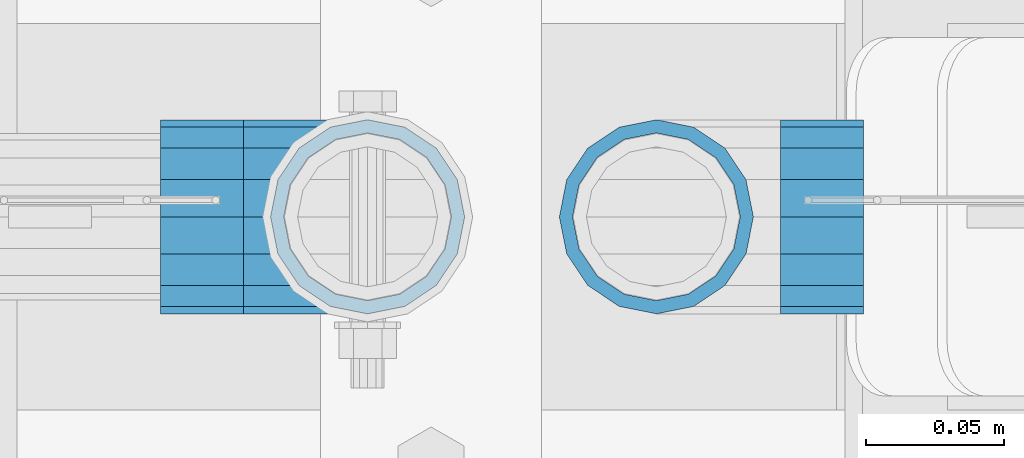
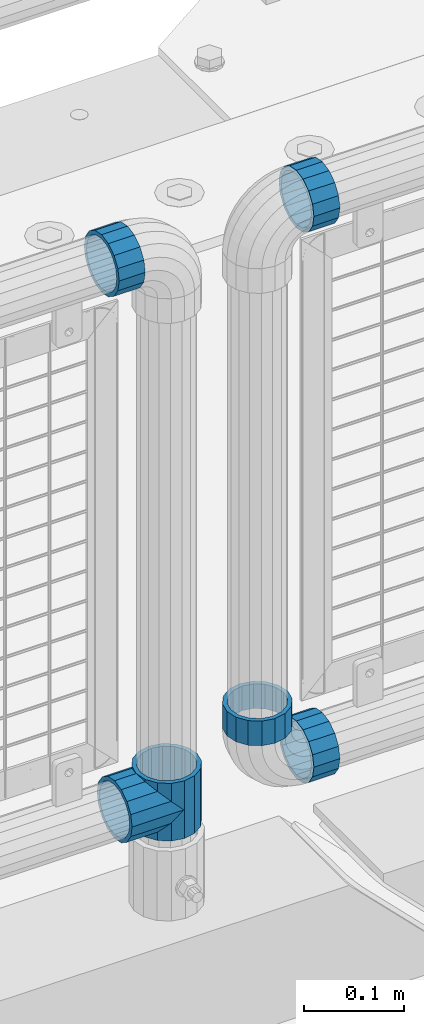
# One storey, part 144 of 219: 6 beams.
"""IFC2X3 building model written with IfcOpenShell, lengths in millimetres."""

import ifcopenshell
import ifcopenshell.guid

model = None  # the IFC model being written
_history = None  # IfcOwnerHistory: only IFC2X3 demands one
_inside = {}  # id of a spatial element -> (the spatial element, [elements in it])
_under = {}  # id of a project, library or spatial element -> (it, [spatial elements below it])
_declared = {}  # id of a project -> (the project, [libraries it declares])
_typed = {}  # id of a type object -> (the type object, [elements of that type])
_made_of = {}  # id of a material, layer set ... -> (it, [elements and type objects made of it])


def new_model(schema):
    """Start an empty IFC model of exactly this schema.

    Asked for "IFC4X3", IfcOpenShell would pick the latest addendum, in which some entities
    have other attributes; the version numbers below select the first issue.
    IFC2X3 requires an IfcOwnerHistory on every rooted entity: one is made here for all.
    """
    global model, _history
    if schema == "IFC4X3":
        model = ifcopenshell.file(schema_version=(4, 3, 0, 0))
    else:
        model = ifcopenshell.file(schema=schema)
    _inside.clear()
    _under.clear()
    _declared.clear()
    _typed.clear()
    _made_of.clear()
    _history = None
    if model.schema == "IFC2X3":
        org = make("IfcOrganization", Name="unknown")
        user = make(
            "IfcPersonAndOrganization",
            ThePerson=make("IfcPerson", FamilyName="unknown"),
            TheOrganization=org,
        )
        app = make(
            "IfcApplication",
            ApplicationDeveloper=org,
            Version="unknown",
            ApplicationFullName="unknown",
            ApplicationIdentifier="unknown",
        )
        _history = make(
            "IfcOwnerHistory",
            OwningUser=user,
            OwningApplication=app,
            ChangeAction="ADDED",
            CreationDate=0,
        )
    return model


def make(cls, **values):
    """One entity of the class cls with the attributes given. An attribute that is None is left unset."""
    return model.create_entity(
        cls, **{name: value for name, value in values.items() if value is not None}
    )


def rooted(cls, **values):
    """An entity with a GlobalId (a new one), such as an element, a storey or a relation."""
    return make(cls, GlobalId=ifcopenshell.guid.new(), OwnerHistory=_history, **values)


def si_unit(unit_type, name, prefix=None):
    """IfcSIUnit, for example si_unit("LENGTHUNIT", "METRE", prefix="MILLI")."""
    return make("IfcSIUnit", UnitType=unit_type, Prefix=prefix, Name=name)


def assignment(units):
    """IfcUnitAssignment: the units of a project."""
    return None if units is None else make("IfcUnitAssignment", Units=units)


def point(xyz):
    """IfcCartesianPoint."""
    return None if xyz is None else make("IfcCartesianPoint", Coordinates=xyz)


def direction(xyz):
    """IfcDirection."""
    return None if xyz is None else make("IfcDirection", DirectionRatios=xyz)


def frame(location, z_axis=None, x_axis=None):
    """IfcAxis2Placement3D, a coordinate frame: its origin and axes. An axis left out is left unset."""
    return make(
        "IfcAxis2Placement3D",
        Location=point(location),
        Axis=direction(z_axis),
        RefDirection=direction(x_axis),
    )


def origin_with_axes():
    """The frame at (0, 0, 0) with the z axis (0, 0, 1) and the x axis (1, 0, 0) written out."""
    return frame((0.0, 0.0, 0.0), z_axis=(0.0, 0.0, 1.0), x_axis=(1.0, 0.0, 0.0))


def place(relative_to, where):
    """IfcLocalPlacement: puts the frame where relative to a parent placement (None: the world)."""
    return make(
        "IfcLocalPlacement", PlacementRelTo=relative_to, RelativePlacement=where
    )


def context(
    kind, dimensions, precision=None, world=None, true_north=None, identifier=None
):
    """IfcGeometricRepresentationContext, for example the 3D "Model" context."""
    return make(
        "IfcGeometricRepresentationContext",
        ContextIdentifier=identifier,
        ContextType=kind,
        CoordinateSpaceDimension=dimensions,
        Precision=precision,
        WorldCoordinateSystem=world,
        TrueNorth=true_north,
    )


def subcontext(parent, identifier, kind, view, scale=None):
    """IfcGeometricRepresentationSubContext, for example "Body" below "Model"."""
    return make(
        "IfcGeometricRepresentationSubContext",
        ContextIdentifier=identifier,
        ContextType=kind,
        ParentContext=parent,
        TargetScale=scale,
        TargetView=view,
    )


def project(units=None, contexts=None):
    """IfcProject with its units and contexts."""
    return rooted(
        "IfcProject",
        Name="project",
        RepresentationContexts=contexts,
        UnitsInContext=assignment(units),
    )


def spatial(cls, under=None, at=None, **own):
    """A site, building, storey or space (cls), placed at a placement, below another one or the project."""
    s = rooted(cls, ObjectPlacement=at, **own)
    if under is not None:
        _under.setdefault(under.id(), (under, []))[1].append(s)
    return s


def faces_of(points, faces, orient=None, outer=None):
    """IfcFace entities. A face is a list of loops; a loop is a list of indices into points, from 0.

    orient and outer hold one flag for each loop. By default every Orientation is true, the
    first loop of a face is its IfcFaceOuterBound and the others are IfcFaceBound.
    """
    made = []
    for i, loops in enumerate(faces):
        bounds = []
        for j, loop in enumerate(loops):
            is_outer = j == 0 if outer is None else outer[i][j]
            bounds.append(
                make(
                    "IfcFaceOuterBound" if is_outer else "IfcFaceBound",
                    Bound=make("IfcPolyLoop", Polygon=[points[k] for k in loop]),
                    Orientation=True if orient is None else orient[i][j],
                )
            )
        made.append(make("IfcFace", Bounds=bounds))
    return made


def faceted_brep(points, faces, orient=None, outer=None, voids=None):
    """IfcFacetedBrep: a solid bounded by flat faces; with voids (closed shells), ...WithVoids."""
    shared = [point(p) for p in points]
    hull = make("IfcClosedShell", CfsFaces=faces_of(shared, faces, orient, outer))
    if voids is None:
        return make("IfcFacetedBrep", Outer=hull)
    return make(
        "IfcFacetedBrepWithVoids",
        Outer=hull,
        Voids=[
            make(cls, CfsFaces=faces_of(shared, fs, o, b)) for cls, fs, o, b in voids
        ],
    )


def shape(context_of_items, identifier, shape_type, items):
    """IfcShapeRepresentation: the items that make up one representation, for example the "Body"."""
    return make(
        "IfcShapeRepresentation",
        ContextOfItems=context_of_items,
        RepresentationIdentifier=identifier,
        RepresentationType=shape_type,
        Items=items,
    )


def material(Name=None, Category=None):
    """IfcMaterial."""
    return make("IfcMaterial", Name=Name, Category=Category)


def made_of(thing, what):
    """Note that an element or type object is made of a material, layer set ...; save() writes the relation."""
    if what is not None:
        _made_of.setdefault(what.id(), (what, []))[1].append(thing)
    return thing


def type_object(cls, material=None, **own):
    """A type object (cls), such as IfcWallType, which elements share."""
    return made_of(rooted(cls, **own), material)


def element(
    cls,
    number,
    at=None,
    inside=None,
    cuts=None,
    type_object=None,
    material=None,
    context=None,
    identifier="Body",
    shape_type=None,
    held_by="IfcProductDefinitionShape",
    body=None,
    shapes=None,
    **own,
):
    """One element of the class cls, such as IfcWall. Its Tag is "e" and its number.

    at: its placement. inside: the storey or other place that contains it. cuts: it is an
    opening in that element (IfcRelVoidsElement). A single representation is given by context,
    identifier, shape_type and body (its items); several are given by shapes. held_by: the class
    of the entity that holds the representations. save() writes the other relations.
    """
    e = rooted(cls, Tag="e%d" % number, ObjectPlacement=at, **own)
    if body is not None:
        shapes = [shape(context, identifier, shape_type, body)]
    if shapes is not None:
        e.Representation = make(held_by, Representations=shapes)
    if inside is not None:
        _inside.setdefault(inside.id(), (inside, []))[1].append(e)
    if cuts is not None:
        rooted(
            "IfcRelVoidsElement", RelatingBuildingElement=cuts, RelatedOpeningElement=e
        )
    if type_object is not None:
        _typed.setdefault(type_object.id(), (type_object, []))[1].append(e)
    return made_of(e, material)


def aggregate(whole, parts):
    """IfcRelAggregates: a whole, such as a stair, and the parts it consists of."""
    return rooted("IfcRelAggregates", RelatingObject=whole, RelatedObjects=parts)


def save(model, path):
    """Write the relations noted so far, then the file.

    IfcRelAggregates (storeys below a building ...), IfcRelContainedInSpatialStructure (elements
    in a storey), IfcRelDefinesByType, IfcRelAssociatesMaterial and IfcRelDeclares: one each for
    every whole, place, type object, material and project.
    """
    for whole, parts in _under.values():
        aggregate(whole, parts)
    for where, things in _inside.values():
        rooted(
            "IfcRelContainedInSpatialStructure",
            RelatedElements=things,
            RelatingStructure=where,
        )
    for kind, things in _typed.values():
        rooted("IfcRelDefinesByType", RelatedObjects=things, RelatingType=kind)
    for what, things in _made_of.values():
        rooted("IfcRelAssociatesMaterial", RelatedObjects=things, RelatingMaterial=what)
    for by, libraries in _declared.values():
        rooted("IfcRelDeclares", RelatingContext=by, RelatedDefinitions=libraries)
    model.write(path)


model = new_model("IFC2X3")

# Units and contexts
model_context = context("Model", 3, precision=1e-05, world=origin_with_axes())
body_context = subcontext(model_context, "Body", "Model", "MODEL_VIEW")
ifc_project = project(units=[si_unit("LENGTHUNIT", "METRE", prefix="MILLI"), si_unit("AREAUNIT", "SQUARE_METRE"), si_unit("VOLUMEUNIT", "CUBIC_METRE"), si_unit("MASSUNIT", "GRAM", prefix="KILO"), si_unit("TIMEUNIT", "SECOND"), si_unit("PLANEANGLEUNIT", "RADIAN"), si_unit("SOLIDANGLEUNIT", "STERADIAN"), si_unit("THERMODYNAMICTEMPERATUREUNIT", "DEGREE_CELSIUS"), si_unit("LUMINOUSINTENSITYUNIT", "LUMEN")], contexts=[model_context])

# Site, building, storey
site_placement = place(None, origin_with_axes())
site = spatial("IfcSite", under=ifc_project, at=site_placement, CompositionType="ELEMENT")
building_placement = place(site_placement, origin_with_axes())
building = spatial("IfcBuilding", under=site, at=building_placement, Name="Standard", CompositionType="ELEMENT")
storey_placement = place(building_placement, origin_with_axes())
storey = spatial("IfcBuildingStorey", under=building, at=storey_placement, Name="Undefined", CompositionType="ELEMENT", Elevation=0.0)

# Beams
ifc_material = material(Name="Misc_Undefined")
beam_type = type_object("IfcBeamType", PredefinedType="NOTDEFINED")
beam_1_placement = place(storey_placement, frame((12227.0, 31664.5, 298.670000000001), z_axis=(0.0, 1.0, 0.0), x_axis=(-1.0, 0.0, 0.0)))
element("IfcBeam", 1, at=beam_1_placement, inside=storey, type_object=beam_type, material=ifc_material, context=body_context, shape_type="Brep", body=[
    faceted_brep([(0.0, 0.0, -35.1500000000015), (13.4513226476338, -13.4513226476329, -32.4743655677703), (13.4513226476338, 13.4513226476329, -32.4743655677703), (27.1226768591096, -21.4606908090117, 21.46069080901), (32.4743655677721, -26.8123795176755, 13.4513226476338), (32.4743655677721, -32.4743655677717, 13.4513226476338), (24.8548033587067, -24.8548033587072, 24.8548033587067), (24.8548033587067, -16.3810424080013, 24.8548033587067), (32.8397438117172, -28.0397438117175, 11.614442172282), (35.1499999999996, -30.35, 0.0), (35.1499999999996, -35.15, 0.0), (32.4743655677721, -26.8123795176712, -13.4513226476338), (32.4743655677721, -32.4743655677717, -13.4513226476338), (32.8397438117172, -28.0397438117175, -11.614442172282), (24.8548033587067, -16.3810424080013, -24.8548033587067), (24.8548033587067, -24.8548033587072, -24.8548033587067), (27.1226768591077, -21.4606908090117, -21.46069080901), (20.0882031229739, -11.6144421722805, -28.0397438117179), (16.6306603983649, 0.0, -30.3499999999985), (20.0882031229739, 11.6144421722805, -28.0397438117179), (24.8548033587067, 16.3810424080013, -24.8548033587067), (24.8548033587067, 24.8548033587072, -24.8548033587067), (27.1226768591077, 21.4606908090117, -21.46069080901), (32.4743655677721, 26.8123795176755, -13.4513226476338), (32.4743655677721, 32.4743655677717, -13.4513226476338), (32.8397438117172, 28.0397438117175, -11.614442172282), (35.1499999999996, 30.35, 0.0), (35.1499999999996, 35.15, 0.0), (32.8397438117172, 28.0397438117175, 11.614442172282), (32.4743655677721, 26.8123795176755, 13.4513226476338), (32.4743655677721, 32.4743655677717, 13.4513226476338), (27.1226768591096, 21.4606908090117, 21.46069080901), (24.8548033587067, 16.3810424080078, 24.8548033587067), (24.8548033587067, 24.8548033587072, 24.8548033587067), (0.0, 0.0, 35.1500000000015), (13.4513226476338, 13.4513226476329, 32.4743655677703), (13.4513226476338, -13.4513226476329, 32.4743655677703), (20.0882031229849, 11.6144421722805, 28.0397438117179), (16.6306603983739, 0.0, 30.3499999999985), (20.0882031229849, -11.6144421722805, 28.0397438117179), (60.1499999999996, -35.15, 0.0), (60.1499999999996, -32.4743655677717, 13.4513226476338), (60.1499999999996, -24.8548033587072, 24.8548033587067), (60.1499999999996, -13.4513226476329, 32.4743655677703), (60.1499999999996, 0.0, 35.1500000000015), (60.1499999999996, -24.8548033587072, -24.8548033587067), (60.1499999999996, -32.4743655677717, -13.4513226476338), (60.1499999999996, -13.4513226476329, -32.4743655677703), (60.1499999999996, 0.0, -35.1500000000015), (60.1499999999996, 13.4513226476329, -32.4743655677703), (60.1499999999996, 24.8548033587072, -24.8548033587067), (60.1499999999996, 32.4743655677717, -13.4513226476338), (60.1499999999996, 35.15, 0.0), (60.1499999999996, 32.4743655677717, 13.4513226476338), (60.1499999999996, 24.8548033587072, 24.8548033587067), (60.1499999999996, 13.4513226476329, 32.4743655677703), (60.1499999999996, -21.4606908090117, 21.46069080901), (60.1499999999996, -11.6144421722805, 28.0397438117179), (60.1499999999996, 0.0, 30.3499999999985), (60.1499999999996, 11.6144421722805, 28.0397438117179), (60.1499999999996, 21.4606908090117, 21.46069080901), (60.1499999999996, 28.0397438117175, 11.614442172282), (60.1499999999996, 30.35, 0.0), (60.1499999999996, 28.0397438117175, -11.614442172282), (60.1499999999996, 21.4606908090117, -21.46069080901), (60.1499999999996, 11.6144421722805, -28.0397438117179), (60.1499999999996, 0.0, -30.3499999999985), (60.1499999999996, -11.6144421722805, -28.0397438117179), (60.1499999999996, -21.4606908090117, -21.46069080901), (60.1499999999996, -28.0397438117175, -11.614442172282), (60.1499999999996, -30.35, 0.0), (60.1499999999996, -28.0397438117175, 11.614442172282)], [[[0, 1, 2]], [[3, 4, 5, 6, 7]], [[8, 9, 10, 5, 4]], [[11, 12, 10, 9, 13]], [[14, 15, 12, 11, 16]], [[2, 1, 15, 14, 17, 18, 19, 20, 21]], [[21, 20, 22, 23, 24]], [[24, 23, 25, 26, 27]], [[27, 26, 28, 29, 30]], [[30, 29, 31, 32, 33]], [[34, 35, 36]], [[33, 32, 37, 38, 39, 7, 6, 36, 35]], [[40, 41, 5, 10]], [[41, 42, 6, 5]], [[42, 43, 36, 6]], [[43, 44, 34, 36]], [[45, 46, 12, 15]], [[47, 45, 15, 1]], [[48, 47, 1, 0]], [[49, 48, 0, 2]], [[50, 49, 2, 21]], [[51, 50, 21, 24]], [[52, 51, 24, 27]], [[53, 52, 27, 30]], [[54, 53, 30, 33]], [[55, 54, 33, 35]], [[44, 55, 35, 34]], [[46, 40, 10, 12]], [[45, 47, 48, 49, 50, 51, 52, 53, 54, 55, 44, 43, 42, 41, 40, 46], [56, 57, 58, 59, 60, 61, 62, 63, 64, 65, 66, 67, 68, 69, 70, 71]], [[59, 58, 38, 37]], [[31, 60, 59, 37, 32]], [[28, 61, 60, 31, 29]], [[62, 61, 28, 26]], [[63, 62, 26, 25]], [[64, 63, 25, 23, 22]], [[65, 64, 22, 20, 19]], [[66, 65, 19, 18]], [[67, 66, 18, 17]], [[16, 68, 67, 17, 14]], [[13, 69, 68, 16, 11]], [[70, 69, 13, 9]], [[71, 70, 9, 8]], [[56, 71, 8, 4, 3]], [[57, 56, 3, 7, 39]], [[58, 57, 39, 38]]]),
])
beam_2_placement = place(storey_placement, frame((12227.0, 31664.5, 333.820000000001), z_axis=(1.0, 0.0, 0.0), x_axis=(0.0, 0.0, -1.0)))
element("IfcBeam", 2, at=beam_2_placement, inside=storey, type_object=beam_type, material=ifc_material, context=body_context, shape_type="Brep", body=[
    faceted_brep([(46.7644421722801, 28.0397438117179, -11.6144421722802), (46.7644421722801, 28.0397438117179, -20.0882031229849), (51.5310424080006, 24.8548033587067, -24.8548033587067), (56.6106908090114, 21.46069080901, -27.1226768591096), (56.6106908090114, 21.46069080901, -21.4606908090118), (61.9623795176703, 13.4513226476338, -32.4743655677721), (63.1897438117172, 11.614442172282, -32.8397438117172), (63.1897438117172, 11.614442172282, -28.0397438117179), (65.4999999999997, 0.0, -35.1499999999996), (65.4999999999997, 0.0, -30.3500000000004), (63.1897438117172, -11.614442172282, -32.839743811719), (63.1897438117172, -11.614442172282, -28.0397438117179), (61.9623795176747, -13.4513226476338, -32.4743655677721), (56.6106908090114, -21.46069080901, -27.1226768591077), (56.6106908090114, -21.46069080901, -21.4606908090118), (51.5310424080006, -24.8548033587067, -24.8548033587067), (46.7644421722801, -28.0397438117179, -20.0882031229739), (46.7644421722801, -28.0397438117179, -11.6144421722802), (35.1499999999996, -30.3499999999985, -16.6306603983649), (35.1499999999996, -30.35, 0.0), (23.5355578277191, -28.0397438117179, -20.0882031229739), (23.5355578277191, -28.0397438117179, -11.6144421722802), (18.7689575919921, -24.8548033587067, -24.8548033587067), (13.6893091909879, -21.46069080901, -27.1226768591077), (13.6893091909879, -21.46069080901, -21.4606908090118), (8.33762048232455, -13.4513226476338, -32.4743655677721), (7.11025618828211, -11.614442172282, -32.839743811719), (7.11025618828211, -11.614442172282, -28.0397438117179), (4.79999999999961, 0.0, -35.1499999999996), (4.79999999999961, 0.0, -30.3500000000004), (7.11025618828211, 11.614442172282, -32.8397438117172), (7.11025618828211, 11.614442172282, -28.0397438117179), (8.33762048232455, 13.4513226476338, -32.4743655677721), (13.6893091909879, 21.46069080901, -27.1226768591096), (13.6893091909879, 21.46069080901, -21.4606908090118), (18.7689575919987, 24.8548033587067, -24.8548033587067), (23.5355578277192, 28.0397438117179, -20.0882031229849), (23.5355578277192, 28.0397438117179, -11.6144421722802), (35.1499999999996, 30.3499999999985, -16.6306603983739), (35.1499999999996, 30.35, 0.0), (0.0, 32.4743655677703, -13.4513226476338), (0.0, 35.1500000000015, 0.0), (70.2999999999993, 35.1500000000015, 0.0), (70.2999999999993, 32.4743655677703, -13.4513226476338), (0.0, 32.4743655677703, 13.4513226476338), (70.2999999999993, 32.4743655677703, 13.4513226476338), (0.0, 24.8548033587067, 24.8548033587067), (70.2999999999993, 24.8548033587067, 24.8548033587067), (0.0, 13.4513226476338, 32.4743655677721), (70.2999999999993, 13.4513226476338, 32.4743655677721), (0.0, 0.0, 35.1500000000015), (70.2999999999993, 0.0, 35.1499999999996), (0.0, -13.4513226476338, 32.4743655677721), (70.2999999999993, -13.4513226476338, 32.4743655677721), (0.0, -24.8548033587067, 24.8548033587067), (70.2999999999993, -24.8548033587067, 24.8548033587067), (0.0, -32.4743655677703, 13.4513226476338), (70.2999999999993, -32.4743655677703, 13.4513226476338), (0.0, -35.1500000000015, 0.0), (70.2999999999993, -35.1500000000015, 0.0), (70.2999999999993, -30.3499999999985, 0.0), (70.2999999999993, -28.0397438117179, -11.6144421722802), (70.2999999999993, -21.46069080901, -21.4606908090118), (70.2999999999993, -11.614442172282, -28.0397438117179), (70.2999999999993, 0.0, -30.3500000000004), (70.2999999999993, 11.614442172282, -28.0397438117179), (70.2999999999993, 21.46069080901, -21.4606908090118), (70.2999999999993, 28.0397438117179, -11.6144421722802), (0.0, -28.0397438117179, -11.6144421722802), (0.0, -30.3499999999985, 0.0), (0.0, -21.46069080901, -21.4606908090118), (0.0, -11.614442172282, -28.0397438117179), (0.0, 0.0, -30.3500000000004), (0.0, 11.614442172282, -28.0397438117179), (0.0, 21.46069080901, -21.4606908090118), (0.0, 28.0397438117179, -11.6144421722802), (0.0, 30.3499999999985, 0.0), (70.2999999999993, 30.3499999999985, 0.0), (0.0, 28.0397438117179, 11.6144421722802), (70.2999999999993, 28.0397438117179, 11.6144421722802), (0.0, 21.46069080901, 21.4606908090118), (70.2999999999993, 21.46069080901, 21.4606908090118), (0.0, 11.614442172282, 28.0397438117179), (70.2999999999993, 11.614442172282, 28.0397438117179), (0.0, 0.0, 30.3500000000004), (70.2999999999993, 0.0, 30.3500000000004), (0.0, -11.614442172282, 28.0397438117179), (70.2999999999993, -11.614442172282, 28.0397438117179), (0.0, -21.46069080901, 21.4606908090118), (70.2999999999993, -21.46069080901, 21.4606908090118), (0.0, -28.0397438117179, 11.6144421722802), (70.2999999999993, -28.0397438117179, 11.6144421722802), (70.2999999999993, -24.8548033587067, -24.8548033587067), (70.2999999999993, -13.4513226476338, -32.4743655677721), (70.2999999999993, 0.0, -35.1499999999996), (70.2999999999993, 13.4513226476338, -32.4743655677721), (70.2999999999993, 24.8548033587067, -24.8548033587067), (70.2999999999993, -32.4743655677703, -13.4513226476338), (0.0, -32.4743655677703, -13.4513226476338), (0.0, 24.8548033587067, -24.8548033587067), (0.0, 13.4513226476338, -32.4743655677721), (0.0, 0.0, -35.1500000000015), (0.0, -13.4513226476338, -32.4743655677721), (0.0, -24.8548033587067, -24.8548033587067)], [[[0, 1, 2, 3, 4]], [[4, 3, 5, 6, 7]], [[7, 6, 8, 9]], [[9, 8, 10, 11]], [[11, 10, 12, 13, 14]], [[14, 13, 15, 16, 17]], [[17, 16, 18, 19]], [[19, 18, 20, 21]], [[21, 20, 22, 23, 24]], [[24, 23, 25, 26, 27]], [[27, 26, 28, 29]], [[29, 28, 30, 31]], [[31, 30, 32, 33, 34]], [[34, 33, 35, 36, 37]], [[37, 36, 38, 39]], [[39, 38, 1, 0]], [[40, 41, 42, 43]], [[41, 44, 45, 42]], [[44, 46, 47, 45]], [[46, 48, 49, 47]], [[48, 50, 51, 49]], [[50, 52, 53, 51]], [[52, 54, 55, 53]], [[54, 56, 57, 55]], [[56, 58, 59, 57]], [[60, 61, 17, 19]], [[61, 62, 14, 17]], [[62, 63, 11, 14]], [[63, 64, 9, 11]], [[64, 65, 7, 9]], [[65, 66, 4, 7]], [[66, 67, 0, 4]], [[68, 69, 19, 21]], [[70, 68, 21, 24]], [[71, 70, 24, 27]], [[72, 71, 27, 29]], [[73, 72, 29, 31]], [[74, 73, 31, 34]], [[75, 74, 34, 37]], [[76, 75, 37, 39]], [[67, 77, 39, 0]], [[78, 76, 39, 77, 79]], [[80, 78, 79, 81]], [[82, 80, 81, 83]], [[84, 82, 83, 85]], [[86, 84, 85, 87]], [[88, 86, 87, 89]], [[90, 88, 89, 91]], [[19, 69, 90, 91, 60]], [[92, 93, 94, 95, 96, 43, 42, 45, 47, 49, 51, 53, 55, 57, 59, 97], [89, 87, 85, 83, 81, 79, 77, 67, 66, 65, 64, 63, 62, 61, 60, 91]], [[58, 98, 97, 59]], [[56, 54, 52, 50, 48, 46, 44, 41, 40, 99, 100, 101, 102, 103, 98, 58], [68, 70, 71, 72, 73, 74, 75, 76, 78, 80, 82, 84, 86, 88, 90, 69]], [[32, 100, 99, 35, 33]], [[28, 101, 100, 32, 30]], [[102, 101, 28, 26, 25]], [[103, 102, 25, 23, 22]], [[15, 92, 97, 98, 103, 22, 20, 18, 16]], [[12, 93, 92, 15, 13]], [[8, 94, 93, 12, 10]], [[95, 94, 8, 6, 5]], [[96, 95, 5, 3, 2]], [[35, 99, 40, 43, 96, 2, 1, 38, 36]]]),
])
beam_3_placement = place(storey_placement, frame((12182.0, 31664.5, 969.85), z_axis=(0.0, 0.0, 1.0), x_axis=(-1.0, 0.0, 0.0)))
element("IfcBeam", 3, at=beam_3_placement, inside=storey, type_object=beam_type, material=ifc_material, context=body_context, shape_type="Brep", body=[
    faceted_brep([(0.0, -30.3499999999985, 0.0), (0.0, -28.0397438117179, 11.6144421722802), (30.0, -28.0397438117179, 11.6144421722805), (30.0, -30.3499999999985, 0.0), (0.0, -21.46069080901, 21.4606908090118), (30.0, -21.46069080901, 21.4606908090117), (0.0, -11.614442172282, 28.0397438117179), (30.0, -11.614442172282, 28.0397438117176), (0.0, 0.0, 30.3500000000004), (30.0, 0.0, 30.35), (0.0, 11.614442172282, 28.0397438117179), (30.0, 11.614442172282, 28.0397438117176), (0.0, 21.46069080901, 21.4606908090118), (30.0, 21.46069080901, 21.4606908090117), (0.0, 28.0397438117179, 11.6144421722802), (30.0, 28.0397438117179, 11.6144421722805), (0.0, 30.3499999999985, 0.0), (30.0, 30.3499999999985, 0.0), (0.0, 28.0397438117179, -11.6144421722802), (30.0, 28.0397438117179, -11.6144421722805), (0.0, 21.46069080901, -21.4606908090118), (30.0, 21.46069080901, -21.4606908090117), (0.0, 11.614442172282, -28.0397438117179), (30.0, 11.614442172282, -28.0397438117176), (0.0, 0.0, -30.3500000000004), (30.0, 0.0, -30.35), (0.0, -11.614442172282, -28.0397438117179), (30.0, -11.614442172282, -28.0397438117176), (0.0, -21.46069080901, -21.4606908090118), (30.0, -21.46069080901, -21.4606908090117), (0.0, -28.0397438117179, -11.6144421722802), (30.0, -28.0397438117179, -11.6144421722805), (0.0, -35.1500000000015, 0.0), (0.0, -32.4743655677703, -13.4513226476338), (30.0, -32.4743655677703, -13.4513226476329), (30.0, -35.1500000000015, 0.0), (0.0, -24.8548033587067, -24.8548033587067), (30.0, -24.8548033587067, -24.8548033587072), (0.0, -13.4513226476338, -32.4743655677721), (30.0, -13.4513226476338, -32.4743655677718), (0.0, 0.0, -35.1500000000015), (30.0, 0.0, -35.15), (0.0, 13.4513226476338, -32.4743655677721), (30.0, 13.4513226476338, -32.4743655677718), (0.0, 24.8548033587067, -24.8548033587067), (30.0, 24.8548033587067, -24.8548033587072), (0.0, 32.4743655677703, -13.4513226476338), (30.0, 32.4743655677703, -13.4513226476329), (0.0, 35.1500000000015, 0.0), (30.0, 35.1500000000015, 0.0), (0.0, 32.4743655677703, 13.4513226476338), (30.0, 32.4743655677703, 13.4513226476329), (0.0, 24.8548033587067, 24.8548033587067), (30.0, 24.8548033587067, 24.8548033587072), (0.0, 13.4513226476338, 32.4743655677721), (30.0, 13.4513226476338, 32.4743655677718), (0.0, 0.0, 35.1500000000015), (30.0, 0.0, 35.15), (0.0, -13.4513226476338, 32.4743655677721), (30.0, -13.4513226476338, 32.4743655677718), (0.0, -24.8548033587067, 24.8548033587067), (30.0, -24.8548033587067, 24.8548033587072), (0.0, -32.4743655677703, 13.4513226476338), (30.0, -32.4743655677703, 13.4513226476329)], [[[0, 1, 2, 3]], [[1, 4, 5, 2]], [[4, 6, 7, 5]], [[6, 8, 9, 7]], [[8, 10, 11, 9]], [[10, 12, 13, 11]], [[12, 14, 15, 13]], [[14, 16, 17, 15]], [[16, 18, 19, 17]], [[18, 20, 21, 19]], [[20, 22, 23, 21]], [[22, 24, 25, 23]], [[24, 26, 27, 25]], [[26, 28, 29, 27]], [[28, 30, 31, 29]], [[30, 0, 3, 31]], [[32, 33, 34, 35]], [[33, 36, 37, 34]], [[36, 38, 39, 37]], [[38, 40, 41, 39]], [[40, 42, 43, 41]], [[42, 44, 45, 43]], [[44, 46, 47, 45]], [[46, 48, 49, 47]], [[48, 50, 51, 49]], [[50, 52, 53, 51]], [[52, 54, 55, 53]], [[54, 56, 57, 55]], [[56, 58, 59, 57]], [[58, 60, 61, 59]], [[60, 62, 63, 61]], [[62, 32, 35, 63]], [[37, 39, 41, 43, 45, 47, 49, 51, 53, 55, 57, 59, 61, 63, 35, 34], [5, 7, 9, 11, 13, 15, 17, 19, 21, 23, 25, 27, 29, 31, 3, 2]], [[62, 60, 58, 56, 54, 52, 50, 48, 46, 44, 42, 40, 38, 36, 33, 32], [30, 28, 26, 24, 22, 20, 18, 16, 14, 12, 10, 8, 6, 4, 1, 0]]]),
])
beam_4_placement = place(storey_placement, frame((12376.61, 31664.5, 298.170000000001), z_axis=(0.0, 0.0, -1.0), x_axis=(1.0, 0.0, 0.0)))
element("IfcBeam", 4, at=beam_4_placement, inside=storey, type_object=beam_type, material=ifc_material, context=body_context, shape_type="Brep", body=[
    faceted_brep([(0.0, -30.3499999999985, 0.0), (0.0, -28.0397438117179, 11.6144421722802), (30.0, -28.0397438117179, 11.6144421722805), (30.0, -30.3499999999985, 0.0), (0.0, -21.46069080901, 21.4606908090118), (30.0, -21.46069080901, 21.4606908090117), (0.0, -11.614442172282, 28.0397438117179), (30.0, -11.614442172282, 28.0397438117176), (0.0, 0.0, 30.3500000000004), (30.0, 0.0, 30.35), (0.0, 11.614442172282, 28.0397438117179), (30.0, 11.614442172282, 28.0397438117176), (0.0, 21.46069080901, 21.4606908090118), (30.0, 21.46069080901, 21.4606908090117), (0.0, 28.0397438117179, 11.6144421722802), (30.0, 28.0397438117179, 11.6144421722805), (0.0, 30.3499999999985, 0.0), (30.0, 30.3499999999985, 0.0), (0.0, 28.0397438117179, -11.6144421722802), (30.0, 28.0397438117179, -11.6144421722805), (0.0, 21.46069080901, -21.4606908090118), (30.0, 21.46069080901, -21.4606908090117), (0.0, 11.614442172282, -28.0397438117179), (30.0, 11.614442172282, -28.0397438117176), (0.0, 0.0, -30.3500000000004), (30.0, 0.0, -30.35), (0.0, -11.614442172282, -28.0397438117179), (30.0, -11.614442172282, -28.0397438117176), (0.0, -21.46069080901, -21.4606908090118), (30.0, -21.46069080901, -21.4606908090117), (0.0, -28.0397438117179, -11.6144421722802), (30.0, -28.0397438117179, -11.6144421722805), (0.0, -35.1500000000015, 0.0), (0.0, -32.4743655677703, -13.4513226476338), (30.0, -32.4743655677703, -13.4513226476329), (30.0, -35.1500000000015, 0.0), (0.0, -24.8548033587067, -24.8548033587067), (30.0, -24.8548033587067, -24.8548033587072), (0.0, -13.4513226476338, -32.4743655677721), (30.0, -13.4513226476338, -32.4743655677718), (0.0, 0.0, -35.1500000000015), (30.0, 0.0, -35.15), (0.0, 13.4513226476338, -32.4743655677721), (30.0, 13.4513226476338, -32.4743655677718), (0.0, 24.8548033587067, -24.8548033587067), (30.0, 24.8548033587067, -24.8548033587072), (0.0, 32.4743655677703, -13.4513226476338), (30.0, 32.4743655677703, -13.4513226476329), (0.0, 35.1500000000015, 0.0), (30.0, 35.1500000000015, 0.0), (0.0, 32.4743655677703, 13.4513226476338), (30.0, 32.4743655677703, 13.4513226476329), (0.0, 24.8548033587067, 24.8548033587067), (30.0, 24.8548033587067, 24.8548033587072), (0.0, 13.4513226476338, 32.4743655677721), (30.0, 13.4513226476338, 32.4743655677718), (0.0, 0.0, 35.1500000000015), (30.0, 0.0, 35.15), (0.0, -13.4513226476338, 32.4743655677721), (30.0, -13.4513226476338, 32.4743655677718), (0.0, -24.8548033587067, 24.8548033587067), (30.0, -24.8548033587067, 24.8548033587072), (0.0, -32.4743655677703, 13.4513226476338), (30.0, -32.4743655677703, 13.4513226476329)], [[[0, 1, 2, 3]], [[1, 4, 5, 2]], [[4, 6, 7, 5]], [[6, 8, 9, 7]], [[8, 10, 11, 9]], [[10, 12, 13, 11]], [[12, 14, 15, 13]], [[14, 16, 17, 15]], [[16, 18, 19, 17]], [[18, 20, 21, 19]], [[20, 22, 23, 21]], [[22, 24, 25, 23]], [[24, 26, 27, 25]], [[26, 28, 29, 27]], [[28, 30, 31, 29]], [[30, 0, 3, 31]], [[32, 33, 34, 35]], [[33, 36, 37, 34]], [[36, 38, 39, 37]], [[38, 40, 41, 39]], [[40, 42, 43, 41]], [[42, 44, 45, 43]], [[44, 46, 47, 45]], [[46, 48, 49, 47]], [[48, 50, 51, 49]], [[50, 52, 53, 51]], [[52, 54, 55, 53]], [[54, 56, 57, 55]], [[56, 58, 59, 57]], [[58, 60, 61, 59]], [[60, 62, 63, 61]], [[62, 32, 35, 63]], [[37, 39, 41, 43, 45, 47, 49, 51, 53, 55, 57, 59, 61, 63, 35, 34], [5, 7, 9, 11, 13, 15, 17, 19, 21, 23, 25, 27, 29, 31, 3, 2]], [[62, 60, 58, 56, 54, 52, 50, 48, 46, 44, 42, 40, 38, 36, 33, 32], [30, 28, 26, 24, 22, 20, 18, 16, 14, 12, 10, 8, 6, 4, 1, 0]]]),
])
beam_5_placement = place(storey_placement, frame((12331.61, 31664.5, 373.170000000002), z_axis=(-1.0, 0.0, 0.0), x_axis=(0.0, 0.0, -1.0)))
element("IfcBeam", 5, at=beam_5_placement, inside=storey, type_object=beam_type, material=ifc_material, context=body_context, shape_type="Brep", body=[
    faceted_brep([(0.0, -30.3499999999985, 0.0), (0.0, -28.0397438117179, 11.6144421722802), (30.0, -28.0397438117179, 11.6144421722805), (30.0, -30.3499999999985, 0.0), (0.0, -21.46069080901, 21.4606908090118), (30.0, -21.46069080901, 21.4606908090117), (0.0, -11.614442172282, 28.0397438117179), (30.0, -11.614442172282, 28.0397438117176), (0.0, 0.0, 30.3500000000004), (30.0, 0.0, 30.35), (0.0, 11.614442172282, 28.0397438117179), (30.0, 11.614442172282, 28.0397438117176), (0.0, 21.46069080901, 21.4606908090118), (30.0, 21.46069080901, 21.4606908090117), (0.0, 28.0397438117179, 11.6144421722802), (30.0, 28.0397438117179, 11.6144421722805), (0.0, 30.3499999999985, 0.0), (30.0, 30.3499999999985, 0.0), (0.0, 28.0397438117179, -11.6144421722802), (30.0, 28.0397438117179, -11.6144421722805), (0.0, 21.46069080901, -21.4606908090118), (30.0, 21.46069080901, -21.4606908090117), (0.0, 11.614442172282, -28.0397438117179), (30.0, 11.614442172282, -28.0397438117176), (0.0, 0.0, -30.3500000000004), (30.0, 0.0, -30.35), (0.0, -11.614442172282, -28.0397438117179), (30.0, -11.614442172282, -28.0397438117176), (0.0, -21.46069080901, -21.4606908090118), (30.0, -21.46069080901, -21.4606908090117), (0.0, -28.0397438117179, -11.6144421722802), (30.0, -28.0397438117179, -11.6144421722805), (0.0, -35.1500000000015, 0.0), (0.0, -32.4743655677703, -13.4513226476338), (30.0, -32.4743655677703, -13.4513226476329), (30.0, -35.1500000000015, 0.0), (0.0, -24.8548033587067, -24.8548033587067), (30.0, -24.8548033587067, -24.8548033587072), (0.0, -13.4513226476338, -32.4743655677721), (30.0, -13.4513226476338, -32.4743655677718), (0.0, 0.0, -35.1500000000015), (30.0, 0.0, -35.15), (0.0, 13.4513226476338, -32.4743655677721), (30.0, 13.4513226476338, -32.4743655677718), (0.0, 24.8548033587067, -24.8548033587067), (30.0, 24.8548033587067, -24.8548033587072), (0.0, 32.4743655677703, -13.4513226476338), (30.0, 32.4743655677703, -13.4513226476329), (0.0, 35.1500000000015, 0.0), (30.0, 35.1500000000015, 0.0), (0.0, 32.4743655677703, 13.4513226476338), (30.0, 32.4743655677703, 13.4513226476329), (0.0, 24.8548033587067, 24.8548033587067), (30.0, 24.8548033587067, 24.8548033587072), (0.0, 13.4513226476338, 32.4743655677721), (30.0, 13.4513226476338, 32.4743655677718), (0.0, 0.0, 35.1500000000015), (30.0, 0.0, 35.15), (0.0, -13.4513226476338, 32.4743655677721), (30.0, -13.4513226476338, 32.4743655677718), (0.0, -24.8548033587067, 24.8548033587067), (30.0, -24.8548033587067, 24.8548033587072), (0.0, -32.4743655677703, 13.4513226476338), (30.0, -32.4743655677703, 13.4513226476329)], [[[0, 1, 2, 3]], [[1, 4, 5, 2]], [[4, 6, 7, 5]], [[6, 8, 9, 7]], [[8, 10, 11, 9]], [[10, 12, 13, 11]], [[12, 14, 15, 13]], [[14, 16, 17, 15]], [[16, 18, 19, 17]], [[18, 20, 21, 19]], [[20, 22, 23, 21]], [[22, 24, 25, 23]], [[24, 26, 27, 25]], [[26, 28, 29, 27]], [[28, 30, 31, 29]], [[30, 0, 3, 31]], [[32, 33, 34, 35]], [[33, 36, 37, 34]], [[36, 38, 39, 37]], [[38, 40, 41, 39]], [[40, 42, 43, 41]], [[42, 44, 45, 43]], [[44, 46, 47, 45]], [[46, 48, 49, 47]], [[48, 50, 51, 49]], [[50, 52, 53, 51]], [[52, 54, 55, 53]], [[54, 56, 57, 55]], [[56, 58, 59, 57]], [[58, 60, 61, 59]], [[60, 62, 63, 61]], [[62, 32, 35, 63]], [[37, 39, 41, 43, 45, 47, 49, 51, 53, 55, 57, 59, 61, 63, 35, 34], [5, 7, 9, 11, 13, 15, 17, 19, 21, 23, 25, 27, 29, 31, 3, 2]], [[62, 60, 58, 56, 54, 52, 50, 48, 46, 44, 42, 40, 38, 36, 33, 32], [30, 28, 26, 24, 22, 20, 18, 16, 14, 12, 10, 8, 6, 4, 1, 0]]]),
])
beam_6_placement = place(storey_placement, frame((12376.61, 31664.5, 969.849999999999), z_axis=(0.0, 0.0, 1.0), x_axis=(1.0, 0.0, 0.0)))
element("IfcBeam", 6, at=beam_6_placement, inside=storey, type_object=beam_type, material=ifc_material, context=body_context, shape_type="Brep", body=[
    faceted_brep([(0.0, -30.3499999999985, 0.0), (0.0, -28.0397438117179, 11.6144421722802), (30.0, -28.0397438117179, 11.6144421722805), (30.0, -30.3499999999985, 0.0), (0.0, -21.46069080901, 21.4606908090118), (30.0, -21.46069080901, 21.4606908090117), (0.0, -11.614442172282, 28.0397438117179), (30.0, -11.614442172282, 28.0397438117176), (0.0, 0.0, 30.3500000000004), (30.0, 0.0, 30.35), (0.0, 11.614442172282, 28.0397438117179), (30.0, 11.614442172282, 28.0397438117176), (0.0, 21.46069080901, 21.4606908090118), (30.0, 21.46069080901, 21.4606908090117), (0.0, 28.0397438117179, 11.6144421722802), (30.0, 28.0397438117179, 11.6144421722805), (0.0, 30.3499999999985, 0.0), (30.0, 30.3499999999985, 0.0), (0.0, 28.0397438117179, -11.6144421722802), (30.0, 28.0397438117179, -11.6144421722805), (0.0, 21.46069080901, -21.4606908090118), (30.0, 21.46069080901, -21.4606908090117), (0.0, 11.614442172282, -28.0397438117179), (30.0, 11.614442172282, -28.0397438117176), (0.0, 0.0, -30.3500000000004), (30.0, 0.0, -30.35), (0.0, -11.614442172282, -28.0397438117179), (30.0, -11.614442172282, -28.0397438117176), (0.0, -21.46069080901, -21.4606908090118), (30.0, -21.46069080901, -21.4606908090117), (0.0, -28.0397438117179, -11.6144421722802), (30.0, -28.0397438117179, -11.6144421722805), (0.0, -35.1500000000015, 0.0), (0.0, -32.4743655677703, -13.4513226476338), (30.0, -32.4743655677703, -13.4513226476329), (30.0, -35.1500000000015, 0.0), (0.0, -24.8548033587067, -24.8548033587067), (30.0, -24.8548033587067, -24.8548033587072), (0.0, -13.4513226476338, -32.4743655677721), (30.0, -13.4513226476338, -32.4743655677718), (0.0, 0.0, -35.1500000000015), (30.0, 0.0, -35.15), (0.0, 13.4513226476338, -32.4743655677721), (30.0, 13.4513226476338, -32.4743655677718), (0.0, 24.8548033587067, -24.8548033587067), (30.0, 24.8548033587067, -24.8548033587072), (0.0, 32.4743655677703, -13.4513226476338), (30.0, 32.4743655677703, -13.4513226476329), (0.0, 35.1500000000015, 0.0), (30.0, 35.1500000000015, 0.0), (0.0, 32.4743655677703, 13.4513226476338), (30.0, 32.4743655677703, 13.4513226476329), (0.0, 24.8548033587067, 24.8548033587067), (30.0, 24.8548033587067, 24.8548033587072), (0.0, 13.4513226476338, 32.4743655677721), (30.0, 13.4513226476338, 32.4743655677718), (0.0, 0.0, 35.1500000000015), (30.0, 0.0, 35.15), (0.0, -13.4513226476338, 32.4743655677721), (30.0, -13.4513226476338, 32.4743655677718), (0.0, -24.8548033587067, 24.8548033587067), (30.0, -24.8548033587067, 24.8548033587072), (0.0, -32.4743655677703, 13.4513226476338), (30.0, -32.4743655677703, 13.4513226476329)], [[[0, 1, 2, 3]], [[1, 4, 5, 2]], [[4, 6, 7, 5]], [[6, 8, 9, 7]], [[8, 10, 11, 9]], [[10, 12, 13, 11]], [[12, 14, 15, 13]], [[14, 16, 17, 15]], [[16, 18, 19, 17]], [[18, 20, 21, 19]], [[20, 22, 23, 21]], [[22, 24, 25, 23]], [[24, 26, 27, 25]], [[26, 28, 29, 27]], [[28, 30, 31, 29]], [[30, 0, 3, 31]], [[32, 33, 34, 35]], [[33, 36, 37, 34]], [[36, 38, 39, 37]], [[38, 40, 41, 39]], [[40, 42, 43, 41]], [[42, 44, 45, 43]], [[44, 46, 47, 45]], [[46, 48, 49, 47]], [[48, 50, 51, 49]], [[50, 52, 53, 51]], [[52, 54, 55, 53]], [[54, 56, 57, 55]], [[56, 58, 59, 57]], [[58, 60, 61, 59]], [[60, 62, 63, 61]], [[62, 32, 35, 63]], [[37, 39, 41, 43, 45, 47, 49, 51, 53, 55, 57, 59, 61, 63, 35, 34], [5, 7, 9, 11, 13, 15, 17, 19, 21, 23, 25, 27, 29, 31, 3, 2]], [[62, 60, 58, 56, 54, 52, 50, 48, 46, 44, 42, 40, 38, 36, 33, 32], [30, 28, 26, 24, 22, 20, 18, 16, 14, 12, 10, 8, 6, 4, 1, 0]]]),
])

save(model, "model.ifc")
